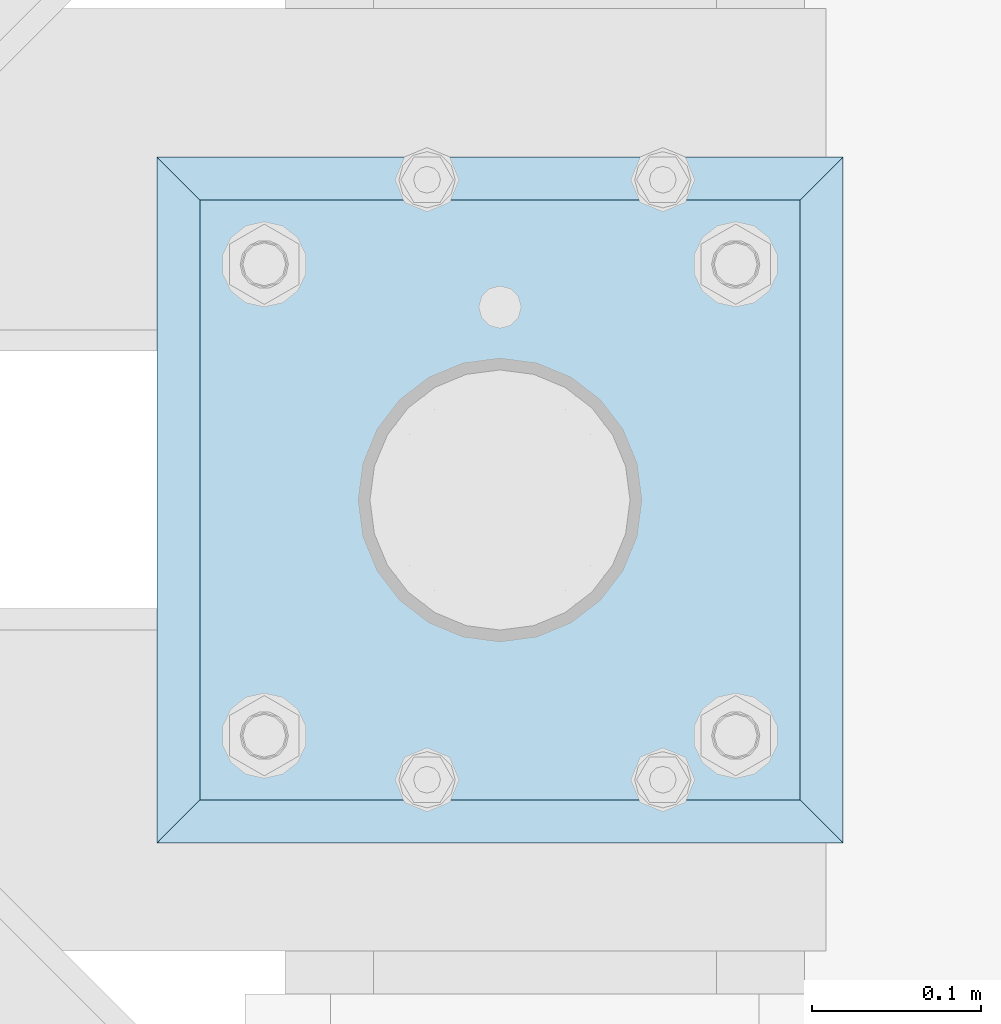
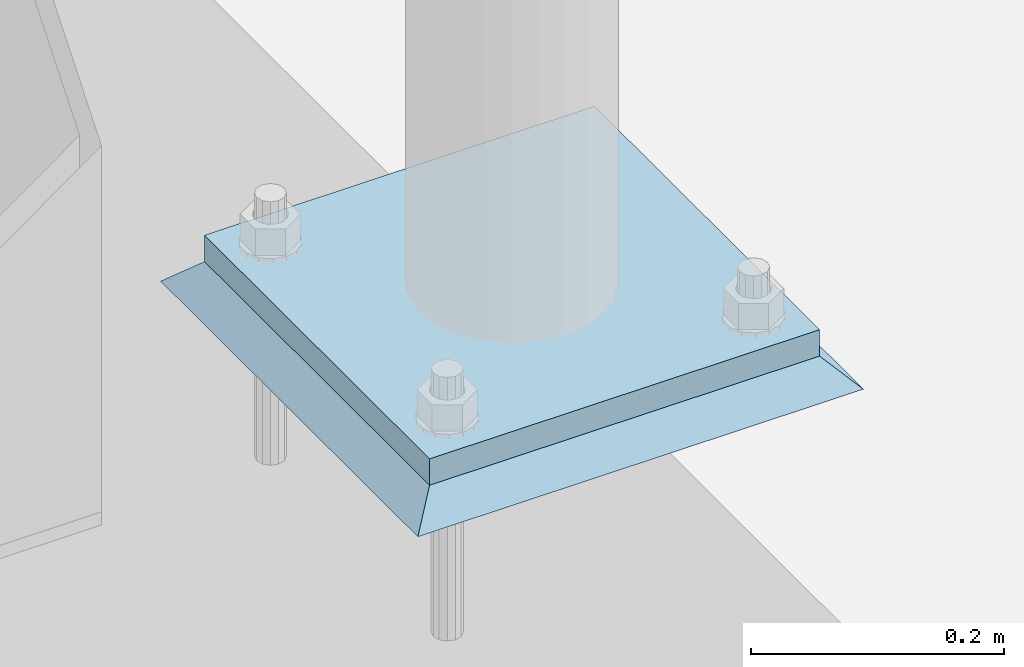
# One storey, part 3041 of 3843: 2 plates, 2 elements without a shape of their own.
"""IFC2X3 building model written with IfcOpenShell, lengths in millimetres."""

from ifc_helpers import new_model, si_unit, frame, origin_with_axes, place, context, subcontext, project, spatial, faceted_brep, material, type_object, element, aggregate, save


model = new_model("IFC2X3")

# Units and contexts
model_context = context("Model", 3, precision=1e-05, world=origin_with_axes())
body_context = subcontext(model_context, "Body", "Model", "MODEL_VIEW")
ifc_project = project(units=[si_unit("LENGTHUNIT", "METRE", prefix="MILLI"), si_unit("AREAUNIT", "SQUARE_METRE"), si_unit("VOLUMEUNIT", "CUBIC_METRE"), si_unit("MASSUNIT", "GRAM", prefix="KILO"), si_unit("TIMEUNIT", "SECOND"), si_unit("PLANEANGLEUNIT", "RADIAN"), si_unit("SOLIDANGLEUNIT", "STERADIAN"), si_unit("THERMODYNAMICTEMPERATUREUNIT", "DEGREE_CELSIUS"), si_unit("LUMINOUSINTENSITYUNIT", "LUMEN")], contexts=[model_context])

# Site, building, storey
site_placement = place(None, origin_with_axes())
site = spatial("IfcSite", under=ifc_project, at=site_placement, CompositionType="ELEMENT")
building_placement = place(site_placement, origin_with_axes())
building = spatial("IfcBuilding", under=site, at=building_placement, Name="Undefined", CompositionType="ELEMENT")
storey_placement = place(building_placement, origin_with_axes())
storey = spatial("IfcBuildingStorey", under=building, at=storey_placement, Name="Undefined", CompositionType="ELEMENT", Elevation=0.0)

# Assembly, plate
assembly_1_placement = place(storey_placement, origin_with_axes())
assembly_1 = element("IfcElementAssembly", 1, at=assembly_1_placement, inside=storey, Name="PIPE_BOLLARD", AssemblyPlace="NOTDEFINED", PredefinedType="RIGID_FRAME")
ifc_material_1 = material(Name="STEEL/A572-50")
plate_type_1 = type_object("IfcPlateType", PredefinedType="NOTDEFINED")
plate_1_placement = place(assembly_1_placement, frame((41857.976550293, 29921.9152178551, 30518.1), z_axis=(0.0, 1.0, 0.0), x_axis=(1.0, 0.0, 0.0)))
plate_1 = element("IfcPlate", 2, at=plate_1_placement, type_object=plate_type_1, material=ifc_material_1, Name="PLATE", context=body_context, shape_type="Brep", body=[
    faceted_brep([(0.0, -12.6999999999971, 0.0), (0.0, -12.7000000000007, 355.600000000006), (0.0, 12.7000000000007, 355.600000000006), (0.0, 12.6999999999971, 0.0), (355.599999999999, -12.7000000000007, 355.600000000006), (355.599999999999, 12.7000000000007, 355.600000000006), (355.599999999999, -12.7000000000007, 0.0), (355.599999999999, 12.7000000000007, 0.0)], [[[0, 1, 2, 3]], [[1, 4, 5, 2]], [[4, 6, 7, 5]], [[6, 0, 3, 7]], [[5, 7, 3, 2]], [[6, 4, 1, 0]]]),
])
aggregate(assembly_1, [plate_1])

assembly_2_placement = place(storey_placement, origin_with_axes())
assembly_2 = element("IfcElementAssembly", 3, at=assembly_2_placement, inside=storey, Name="GROUT", AssemblyPlace="NOTDEFINED", PredefinedType="REINFORCEMENT_UNIT")
ifc_material_2 = material(Name="CONCRETE/Concrete_Undefined")
plate_type_2 = type_object("IfcPlateType", PredefinedType="NOTDEFINED")
plate_2_placement = place(assembly_2_placement, frame((41832.576550293, 29896.5152178551, 30492.7), z_axis=(0.0, 1.0, 0.0), x_axis=(1.0, 0.0, 0.0)))
plate_2 = element("IfcPlate", 4, at=plate_2_placement, type_object=plate_type_2, material=ifc_material_2, Name="GROUT", context=body_context, shape_type="Brep", body=[
    faceted_brep([(25.4000000001906, -12.6999999998552, 380.999999999505), (0.0, 12.7000000000007, 406.399999999994), (0.0, 12.6999999999971, 0.0), (25.4000000001906, -12.6999999999898, 25.4000000004453), (380.999999999833, -12.6999999998588, 25.4000000004453), (406.400000000001, 12.7000000000007, 0.0), (406.400000000001, 12.7000000000007, 406.399999999994), (380.999999999833, -12.6999999999898, 380.999999999505)], [[[0, 1, 2, 3]], [[4, 5, 6, 7]], [[4, 7, 0, 3]], [[5, 4, 3, 2]], [[6, 5, 2, 1]], [[7, 6, 1, 0]]]),
])
aggregate(assembly_2, [plate_2])

save(model, "model.ifc")
